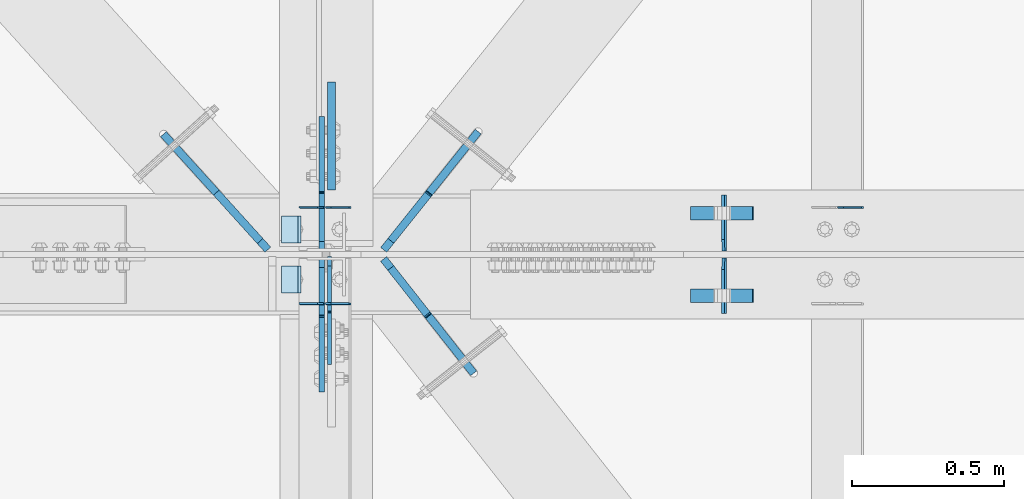
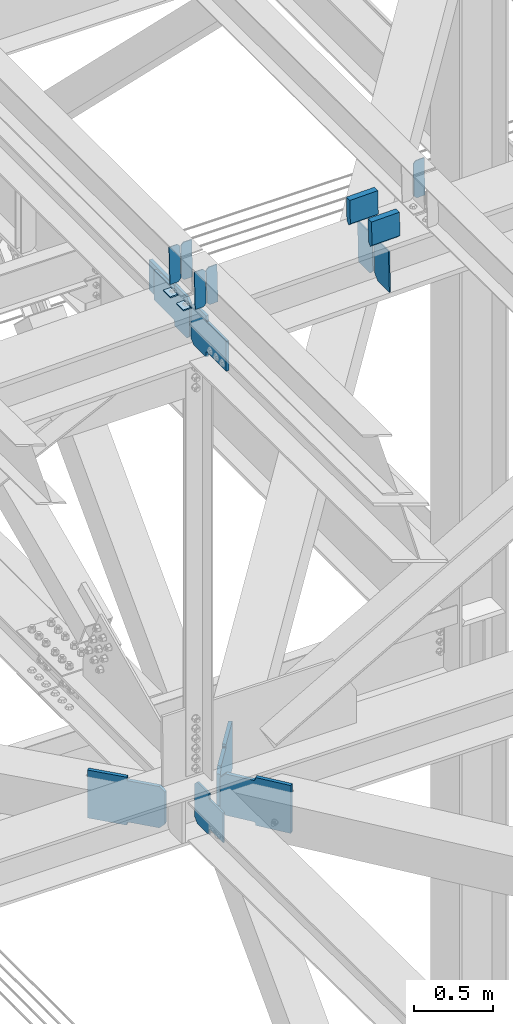
# One storey, part 3488 of 3843: 18 plates, 6 elements without a shape of their own.
"""IFC2X3 building model written with IfcOpenShell, lengths in millimetres."""

from ifc_helpers import new_model, si_unit, frame, origin_with_axes, place, context, subcontext, project, spatial, faceted_brep, material, type_object, element, aggregate, save


model = new_model("IFC2X3")

# Units and contexts
model_context = context("Model", 3, precision=1e-05, world=origin_with_axes())
body_context = subcontext(model_context, "Body", "Model", "MODEL_VIEW")
ifc_project = project(units=[si_unit("LENGTHUNIT", "METRE", prefix="MILLI"), si_unit("AREAUNIT", "SQUARE_METRE"), si_unit("VOLUMEUNIT", "CUBIC_METRE"), si_unit("MASSUNIT", "GRAM", prefix="KILO"), si_unit("TIMEUNIT", "SECOND"), si_unit("PLANEANGLEUNIT", "RADIAN"), si_unit("SOLIDANGLEUNIT", "STERADIAN"), si_unit("THERMODYNAMICTEMPERATUREUNIT", "DEGREE_CELSIUS"), si_unit("LUMINOUSINTENSITYUNIT", "LUMEN")], contexts=[model_context])

# Site, building, storey
site_placement = place(None, origin_with_axes())
site = spatial("IfcSite", under=ifc_project, at=site_placement, CompositionType="ELEMENT")
building_placement = place(site_placement, origin_with_axes())
building = spatial("IfcBuilding", under=site, at=building_placement, Name="Undefined", CompositionType="ELEMENT")
storey_placement = place(building_placement, origin_with_axes())
storey = spatial("IfcBuildingStorey", under=building, at=storey_placement, Name="Undefined", CompositionType="ELEMENT", Elevation=0.0)

# Assembly, plates
assembly_1_placement = place(storey_placement, origin_with_axes())
assembly_1 = element("IfcElementAssembly", 1, at=assembly_1_placement, inside=storey, Name="BEAM", AssemblyPlace="NOTDEFINED", PredefinedType="RIGID_FRAME")
ifc_material = material(Name="STEEL/A572-50")
plate_type_1 = type_object("IfcPlateType", PredefinedType="NOTDEFINED")
plate_1_placement = place(assembly_1_placement, frame((70338.6964783819, 84140.1262089533, 46159.7668452327), z_axis=(-0.0211520977514592, 0.00183800499970675, 0.999774579842043), x_axis=(-0.999776269352655, -3.88860000349027e-05, -0.021152062007432)))
plate_1 = element("IfcPlate", 2, at=plate_1_placement, type_object=plate_type_1, material=ifc_material, Name="PLATE", context=body_context, shape_type="Brep", body=[
    faceted_brep([(0.0, -3.17499999999927, 0.0), (6.83940015733242e-10, -3.17499999996653, 288.924999998613), (6.54836185276508e-10, 3.17500000001746, 288.924999998591), (0.0, 3.17499999999927, 0.0), (60.3250007643655, -3.17500000017753, 288.924999998606), (60.3250007643219, 3.17499999979918, 288.924999998584), (79.3750000013097, -3.17500000025029, 269.875000761494), (79.375000001266, 3.17499999972642, 269.875000761487), (79.375000000713, -3.17500000026484, 19.0499992370605), (79.3750000006985, 3.17499999971187, 19.0499992370533), (60.325000763667, -3.17500000020664, -1.45519152283669e-11), (60.3250007636234, 3.17499999977736, -3.63797880709171e-11)], [[[0, 1, 2, 3]], [[1, 4, 5, 2]], [[4, 6, 7, 5]], [[6, 8, 9, 7]], [[8, 10, 11, 9]], [[10, 0, 3, 11]], [[5, 7, 9, 11, 3, 2]], [[10, 8, 6, 4, 1, 0]]]),
])
plate_2_placement = place(assembly_1_placement, frame((70252.9906576917, 84140.1228754193, 46157.9535846961), z_axis=(-0.0211520977514592, 0.00183800499970675, 0.999774579842043), x_axis=(-0.999776269352655, -3.88860000349027e-05, -0.021152062007432)))
plate_2 = element("IfcPlate", 3, at=plate_2_placement, type_object=plate_type_1, material=ifc_material, Name="PLATE", context=body_context, shape_type="Brep", body=[
    faceted_brep([(4.36557456851006e-11, -3.17499999998836, 19.0499992370969), (6.11180439591408e-10, -3.17499999996653, 269.875000761516), (5.96628524363041e-10, 3.17500000001746, 269.875000761502), (1.45519152283669e-11, 3.17499999998836, 19.0499992370824), (19.0499992376572, -3.17500000003201, 288.924999998606), (19.0499992376281, 3.1749999999447, 288.924999998584), (79.3750000013242, -3.17500000025029, 288.924999998591), (79.3750000013097, 3.1749999997337, 288.92499999857), (79.3750000006548, -3.17500000026484, -2.18278728425503e-11), (79.3750000006403, 3.17499999969732, -2.91038304567337e-11), (19.0499992370023, -3.17500000005384, 0.0), (19.0499992369587, 3.17499999992287, -1.45519152283669e-11)], [[[0, 1, 2, 3]], [[1, 4, 5, 2]], [[4, 6, 7, 5]], [[6, 8, 9, 7]], [[8, 10, 11, 9]], [[10, 0, 3, 11]], [[5, 7, 9, 11, 3, 2]], [[10, 8, 6, 4, 1, 0]]]),
])

assembly_2_placement = place(storey_placement, origin_with_axes())
assembly_2 = element("IfcElementAssembly", 4, at=assembly_2_placement, inside=storey, Name="BEAM", AssemblyPlace="NOTDEFINED", PredefinedType="RIGID_FRAME")
plate_3_placement = place(assembly_2_placement, frame((70338.6964783509, 83820.9062473809, 46161.3065349076), z_axis=(-0.0211520981982467, 0.00763743000170506, 0.999747097222483), x_axis=(-0.999776269343203, -0.000161584000118267, -0.0211514810072338)))
plate_3 = element("IfcPlate", 5, at=plate_3_placement, type_object=plate_type_1, material=ifc_material, Name="PLATE", context=body_context, shape_type="Brep", body=[
    faceted_brep([(0.0, -3.17499999999927, 0.0), (6.83940015733242e-10, -3.17499999996653, 288.924999998613), (6.54836185276508e-10, 3.17500000001746, 288.924999998591), (0.0, 3.17499999999927, 0.0), (60.3250007643655, -3.17500000017753, 288.924999998606), (60.3250007643219, 3.17499999979918, 288.924999998584), (79.3750000013097, -3.17500000025029, 269.875000761494), (79.375000001266, 3.17499999972642, 269.875000761487), (79.375000000713, -3.17500000026484, 19.0499992370605), (79.3750000006985, 3.17499999971187, 19.0499992370533), (60.325000763667, -3.17500000020664, -1.45519152283669e-11), (60.3250007636234, 3.17499999977736, -3.63797880709171e-11)], [[[0, 1, 2, 3]], [[1, 4, 5, 2]], [[4, 6, 7, 5]], [[6, 8, 9, 7]], [[8, 10, 11, 9]], [[10, 0, 3, 11]], [[5, 7, 9, 11, 3, 2]], [[10, 8, 6, 4, 1, 0]]]),
])
plate_4_placement = place(assembly_2_placement, frame((70252.9906576605, 83820.8923956074, 46159.4933242146), z_axis=(-0.0211520981982467, 0.00763743000170506, 0.999747097222483), x_axis=(-0.999776269343203, -0.000161584000118267, -0.0211514810072338)))
plate_4 = element("IfcPlate", 6, at=plate_4_placement, type_object=plate_type_1, material=ifc_material, Name="PLATE", context=body_context, shape_type="Brep", body=[
    faceted_brep([(4.36557456851006e-11, -3.17499999998836, 19.0499992370969), (6.11180439591408e-10, -3.17499999996653, 269.875000761516), (5.96628524363041e-10, 3.17500000001746, 269.875000761502), (1.45519152283669e-11, 3.17499999998836, 19.0499992370824), (19.0499992376572, -3.17500000003201, 288.924999998606), (19.0499992376281, 3.1749999999447, 288.924999998584), (79.3750000013242, -3.17500000025029, 288.924999998591), (79.3750000013097, 3.1749999997337, 288.92499999857), (79.3750000006548, -3.17500000026484, -2.18278728425503e-11), (79.3750000006403, 3.17499999969732, -2.91038304567337e-11), (19.0499992370023, -3.17500000005384, 0.0), (19.0499992369587, 3.17499999992287, -1.45519152283669e-11)], [[[0, 1, 2, 3]], [[1, 4, 5, 2]], [[4, 6, 7, 5]], [[6, 8, 9, 7]], [[8, 10, 11, 9]], [[10, 0, 3, 11]], [[5, 7, 9, 11, 3, 2]], [[10, 8, 6, 4, 1, 0]]]),
])

# Assembly, plate
assembly_3_placement = place(storey_placement, origin_with_axes())
assembly_3 = element("IfcElementAssembly", 7, at=assembly_3_placement, inside=storey, Name="BEAM", AssemblyPlace="NOTDEFINED", PredefinedType="RIGID_FRAME")
plate_5_placement = place(assembly_3_placement, frame((72027.7964783475, 84140.0986588456, 46196.3035666869), z_axis=(-0.0211520984278759, 0.00193018200022925, 0.999774406118472), x_axis=(-0.999776269338344, -4.08370000134752e-05, -0.0211520590071558)))
plate_5 = element("IfcPlate", 8, at=plate_5_placement, type_object=plate_type_1, material=ifc_material, Name="PLATE", context=body_context, shape_type="Brep", body=[
    faceted_brep([(0.0, -3.17499999999927, 0.0), (6.83940015733242e-10, -3.17499999996653, 288.924999998613), (6.54836185276508e-10, 3.17500000001746, 288.924999998591), (0.0, 3.17499999999927, 0.0), (60.3250007643655, -3.17500000017753, 288.924999998606), (60.3250007643219, 3.17499999979918, 288.924999998584), (79.3750000013097, -3.17500000025029, 269.875000761494), (79.375000001266, 3.17499999972642, 269.875000761487), (79.375000000713, -3.17500000026484, 19.0499992370605), (79.3750000006985, 3.17499999971187, 19.0499992370533), (60.325000763667, -3.17500000020664, -1.45519152283669e-11), (60.3250007636234, 3.17499999977736, -3.63797880709171e-11)], [[[0, 1, 2, 3]], [[1, 4, 5, 2]], [[4, 6, 7, 5]], [[6, 8, 9, 7]], [[8, 10, 11, 9]], [[10, 0, 3, 11]], [[5, 7, 9, 11, 3, 2]], [[10, 8, 6, 4, 1, 0]]]),
])
aggregate(assembly_3, [plate_5])

# Assembly, plates
assembly_4_placement = place(storey_placement, origin_with_axes())
assembly_4 = element("IfcElementAssembly", 9, at=assembly_4_placement, inside=storey, Name="BEAM", AssemblyPlace="NOTDEFINED", PredefinedType="RIGID_FRAME")
plate_type_2 = type_object("IfcPlateType", PredefinedType="NOTDEFINED")
plate_6_placement = place(assembly_4_placement, frame((71572.1678113565, 83789.8375, 45819.98476757), z_axis=(-0.0216342480057937, 0.0, 0.999765952267441), x_axis=(0.0, 1.0, 0.0)))
plate_6 = element("IfcPlate", 10, at=plate_6_placement, type_object=plate_type_2, material=ifc_material, Name="PL", context=body_context, shape_type="Brep", body=[
    faceted_brep([(0.0, -4.76249999999709, 0.0), (0.0, -4.76249999785796, 317.500000005042), (0.0, 4.76250000210712, 317.50000000505), (0.0, 4.76249999999709, 0.0), (146.050001525873, -4.76249999785796, 317.500000005042), (146.050001525873, 4.76250000210712, 317.50000000505), (184.149999999994, -4.76249999810534, 279.400001530797), (184.149999999994, 4.76250000185973, 279.400001530805), (184.149999999994, -4.7624999997206, 38.0999984742448), (184.149999999994, 4.76250000022992, 38.0999984742448), (146.049999999988, -4.76250000000073, 0.0), (146.049999999988, 4.76250000000073, 0.0)], [[[0, 1, 2, 3]], [[1, 4, 5, 2]], [[4, 6, 7, 5]], [[6, 8, 9, 7]], [[8, 10, 11, 9]], [[10, 0, 3, 11]], [[5, 7, 9, 11, 3, 2]], [[10, 8, 6, 4, 1, 0]]]),
])
plate_7_placement = place(assembly_4_placement, frame((71572.1678113565, 83996.2125, 45819.98476757), z_axis=(-0.0216342480057937, 0.0, 0.999765952267441), x_axis=(0.0, 1.0, 0.0)))
plate_7 = element("IfcPlate", 11, at=plate_7_placement, type_object=plate_type_2, material=ifc_material, Name="PL", context=body_context, shape_type="Brep", body=[
    faceted_brep([(0.0, -4.76250000000073, 38.0999999999985), (0.0, -4.76249999810534, 279.400001530797), (0.0, 4.76250000185973, 279.400001530805), (0.0, 4.76250000000073, 38.0999999999985), (38.0999984741211, -4.76249999785796, 317.500000005042), (38.0999984741211, 4.76250000210712, 317.50000000505), (184.150000000009, -4.76249999999709, 317.5), (184.150000000009, 4.76249999999709, 317.5), (184.150000000009, -4.76249999999709, 0.0), (184.150000000009, 4.76249999999709, 0.0), (38.0999984741211, -4.76249999996799, 0.0), (38.0999984741211, 4.76249999998254, 0.0)], [[[0, 1, 2, 3]], [[1, 4, 5, 2]], [[4, 6, 7, 5]], [[6, 8, 9, 7]], [[8, 10, 11, 9]], [[10, 0, 3, 11]], [[5, 7, 9, 11, 3, 2]], [[10, 8, 6, 4, 1, 0]]]),
])
plate_type_3 = type_object("IfcPlateType", PredefinedType="NOTDEFINED")
plate_8_placement = place(assembly_4_placement, frame((71458.4330476478, 84121.228125, 46376.3164907603), z_axis=(0.0217666070074993, 0.0, -0.999763079343992), x_axis=(0.999763079343992, 0.0, 0.0217666070075027)))
plate_8 = element("IfcPlate", 12, at=plate_8_placement, type_object=plate_type_3, material=ifc_material, Name="PLATE", context=body_context, shape_type="Brep", body=[
    faceted_brep([(203.200005058941, -22.2250000000058, -1.16415321826935e-10), (7.27595761418343e-12, -22.2250000000058, -7.27595761418343e-12), (7.27595761418343e-12, 22.2250000000058, -7.27595761418343e-12), (203.200005058941, 22.2250000000058, -1.16415321826935e-10), (203.838531807472, -22.2250000000058, 0.00187068080413155), (203.838531807472, 22.2250000000058, 0.00187068080413155), (203.310341304641, -22.2250000000058, 180.861817383484), (0.04046799018397, -22.2250000000058, 180.907287948779), (203.245434494536, 0.0133131837355904, 203.086833080139), (0.0454396034692763, 0.0133129994646879, 203.132287829787), (0.0404679902494536, 22.2250000000058, 180.907288225317), (203.310341303353, 22.2250000000058, 180.861817822159)], [[[0, 1, 2, 3]], [[4, 0, 3, 5]], [[1, 0, 4, 6, 7]], [[7, 6, 8, 9]], [[2, 1, 7, 9, 10]], [[5, 3, 2, 10, 11]], [[6, 4, 5, 11, 8]], [[10, 9, 8, 11]]]),
])
plate_9_placement = place(assembly_4_placement, frame((71458.4330476478, 83848.178125, 46376.3164907603), z_axis=(0.0217666070074993, 0.0, -0.999763079343992), x_axis=(0.999763079343992, 0.0, 0.0217666070075027)))
plate_9 = element("IfcPlate", 13, at=plate_9_placement, type_object=plate_type_3, material=ifc_material, Name="PLATE", context=body_context, shape_type="Brep", body=[
    faceted_brep([(203.200005058941, -22.2250000000058, -1.16415321826935e-10), (7.27595761418343e-12, -22.2250000000058, -7.27595761418343e-12), (7.27595761418343e-12, 22.2250000000058, -7.27595761418343e-12), (203.200005058941, 22.2250000000058, -1.16415321826935e-10), (203.838531807472, -22.2250000000058, 0.00187068080413155), (203.838531807472, 22.2250000000058, 0.00187068080413155), (203.310341304641, -22.2250000000058, 180.861817383484), (0.04046799018397, -22.2250000000058, 180.907287948779), (203.245434494536, 0.0133131837355904, 203.086833080139), (0.0454396034692763, 0.0133129994646879, 203.132287829787), (0.0404679902494536, 22.2250000000058, 180.907288225317), (203.310341303353, 22.2250000000058, 180.861817822159)], [[[0, 1, 2, 3]], [[4, 0, 3, 5]], [[1, 0, 4, 6, 7]], [[7, 6, 8, 9]], [[2, 1, 7, 9, 10]], [[5, 3, 2, 10, 11]], [[6, 4, 5, 11, 8]], [[10, 9, 8, 11]]]),
])

# Plate
plate_type_4 = type_object("IfcPlateType", PredefinedType="NOTDEFINED")
plate_10_placement = place(assembly_1_placement, frame((70173.7677266369, 84112.0999999999, 46150.2113018201), z_axis=(0.0, -1.0, 0.0), x_axis=(-0.999776270257024, 0.0, -0.0211520550054595)))
plate_10 = element("IfcPlate", 14, at=plate_10_placement, type_object=plate_type_4, material=ifc_material, Name="PLATE", context=body_context, shape_type="Brep", body=[
    faceted_brep([(9.52499999982683, -4.7625000001135, 88.8999999999942), (0.0, 4.76249999999709, 88.9000015258789), (0.0, 4.76249999999709, 0.0), (9.52499999981956, -4.76249999999709, 0.0), (63.4999984608512, -4.76249999988795, 88.8999999999796), (63.4999984608367, -4.76249999988795, -1.45519152283669e-11), (63.4999984608221, 4.76250000013533, -1.45519152283669e-11), (63.4999984608367, 4.76250000013533, 88.8999999999796)], [[[0, 1, 2, 3]], [[4, 5, 6, 7]], [[5, 4, 0, 3]], [[6, 5, 3, 2]], [[7, 6, 2, 1]], [[4, 7, 1, 0]]]),
])

aggregate(assembly_1, [plate_1, plate_2, plate_10])

plate_11_placement = place(assembly_2_placement, frame((70173.7677266369, 83947.0000015258, 46150.2113018201), z_axis=(0.0, -1.0, 0.0), x_axis=(-0.999776270257024, 0.0, -0.0211520550054595)))
plate_11 = element("IfcPlate", 15, at=plate_11_placement, type_object=plate_type_4, material=ifc_material, Name="PLATE", context=body_context, shape_type="Brep", body=[
    faceted_brep([(9.52499999982683, -4.7625000001135, 88.8999999999942), (0.0, 4.76249999999709, 88.9000015258789), (0.0, 4.76249999999709, 0.0), (9.52499999981956, -4.76249999999709, 0.0), (63.4999984608512, -4.76249999988795, 88.8999999999796), (63.4999984608367, -4.76249999988795, -1.45519152283669e-11), (63.4999984608221, 4.76250000013533, -1.45519152283669e-11), (63.4999984608367, 4.76250000013533, 88.8999999999796)], [[[0, 1, 2, 3]], [[4, 5, 6, 7]], [[5, 4, 0, 3]], [[6, 5, 3, 2]], [[7, 6, 2, 1]], [[4, 7, 1, 0]]]),
])

aggregate(assembly_2, [plate_3, plate_4, plate_11])

# Assembly, plate
assembly_5_placement = place(storey_placement, origin_with_axes())
assembly_5 = element("IfcElementAssembly", 16, at=assembly_5_placement, inside=storey, Name="BEAM", AssemblyPlace="NOTDEFINED", PredefinedType="RIGID_FRAME")
plate_type_5 = type_object("IfcPlateType", PredefinedType="NOTDEFINED")
plate_12_placement = place(assembly_5_placement, frame((70267.5125000302, 83977.9562500182, 42135.819818912), z_axis=(0.0, -0.707106781186682, 0.707106781186413), x_axis=(0.0, -0.707106781186548, -0.707106781186548)))
plate_12 = element("IfcPlate", 17, at=plate_12_placement, type_object=plate_type_5, material=ifc_material, Name="PLATE", context=body_context, shape_type="Brep", body=[
    faceted_brep([(0.0, -6.3499999046162, 0.0), (-179.600813047069, -6.35000000000582, 179.600813047073), (-179.600813047069, 6.35000000000582, 179.600813047073), (7.27595761418343e-12, 6.3499999046162, 0.0), (-179.600813047073, -6.35000000000582, 224.502093652191), (-179.600813047073, 6.35000000000582, 224.502093652191), (-75.7666016477051, -6.35000000000582, 328.336305051562), (-75.7666016477051, 6.35000000000582, 328.336305051562), (-54.6267979619151, -6.35000000000582, 307.196501396702), (-54.6267979619151, 6.35000000000582, 307.196501396702), (-50.5066214937542, -6.35000000000582, 304.443487496235), (-50.5066214937542, 6.35000000000582, 304.443487496235), (-45.6465419757005, -6.35000000000582, 303.476757573677), (-45.6465419757005, 6.35000000000582, 303.476757573677), (-40.7864624576323, -6.35000000000582, 304.443487496279), (-40.7864624576323, 6.35000000000582, 304.443487496279), (-36.6662859894568, -6.35000000000582, 307.196501396786), (-36.6662859894568, 6.35000000000582, 307.196501396786), (80.0770437083847, -6.35000000000582, 423.939831094605), (80.0770437083847, 6.35000000000582, 423.939831094605), (241.721653886838, -6.35000000000582, 262.295220916116), (241.721653886838, 6.35000000000582, 262.295220916116), (124.978324188996, -6.35000000000582, 145.551891218296), (124.978324188996, 6.35000000000582, 145.551891218296), (122.225310288486, -6.35000000000582, 141.431714750117), (122.225310288486, 6.35000000000582, 141.431714750117), (121.258580365873, -6.35000000000582, 136.571635232071), (121.258580365873, 6.35000000000582, 136.571635232071), (122.225310288428, -6.35000000000582, 131.711555714002), (122.225310288428, 6.35000000000582, 131.711555714002), (124.978324188909, -6.35000000000582, 127.591379245863), (124.978324188909, 6.35000000000582, 127.591379245863), (148.735492004496, -6.35000000000582, 103.834211399357), (148.735492004496, 6.35000000000582, 103.834211399357), (44.9012806051323, -6.35000000000582, -1.45519152283669e-11), (44.9012806051323, 6.35000000000582, -1.45519152283669e-11)], [[[0, 1, 2, 3]], [[1, 4, 5, 2]], [[4, 6, 7, 5]], [[6, 8, 9, 7]], [[8, 10, 11, 9]], [[10, 12, 13, 11]], [[12, 14, 15, 13]], [[14, 16, 17, 15]], [[16, 18, 19, 17]], [[18, 20, 21, 19]], [[20, 22, 23, 21]], [[22, 24, 25, 23]], [[24, 26, 27, 25]], [[26, 28, 29, 27]], [[28, 30, 31, 29]], [[30, 32, 33, 31]], [[32, 34, 35, 33]], [[34, 0, 3, 35]], [[5, 7, 9, 11, 13, 15, 17, 19, 21, 23, 25, 27, 29, 31, 33, 35, 3, 2]], [[34, 32, 30, 28, 26, 24, 22, 20, 18, 16, 14, 12, 10, 8, 6, 4, 1, 0]]]),
])

# Plate
plate_type_6 = type_object("IfcPlateType", PredefinedType="NOTDEFINED")
plate_13_placement = place(assembly_4_placement, frame((70242.1124998361, 83996.2125, 45823.1590276267), z_axis=(0.0, 0.707106781186548, 0.707106781186548), x_axis=(5.70000238222118e-08, 0.707106781186546, -0.707106781186546)))
plate_13 = element("IfcPlate", 18, at=plate_13_placement, type_object=plate_type_6, material=ifc_material, Name="PLATE", context=body_context, shape_type="Brep", body=[
    faceted_brep([(0.0, -9.52500000000146, 0.0), (-179.366715657274, -9.52499999999418, 179.366715657248), (-179.366715657274, 9.52499999999418, 179.366715657248), (0.0, 9.52500000000146, 0.0), (-179.366715656826, -9.52499999999418, 224.267996262832), (-179.366715656826, 9.52499999999418, 224.267996262832), (-68.2360461568533, -9.52499999999418, 335.398665762827), (-68.2360461568533, 9.52499999999418, 335.398665762827), (-46.1232264977771, -9.52499999999418, 313.285846103783), (-46.1232264977771, 9.52499999999418, 313.285846103783), (-42.003050029638, -9.52499999999418, 310.532832203317), (-42.003050029638, 9.52499999999418, 310.532832203317), (-37.1429705115806, -9.52499999999418, 309.566102280762), (-37.1429705115806, 9.52499999999418, 309.566102280762), (-32.2828909935233, -9.52499999999418, 310.53283220336), (-32.2828909935233, 9.52499999999418, 310.53283220336), (-28.1627145253442, -9.52499999999418, 313.28584610387), (-28.1627145253442, 9.52499999999418, 313.28584610387), (142.462151912587, -9.52499999999418, 483.910712541838), (142.462151912587, 9.52499999999418, 483.910712541838), (304.106762091076, -9.52499999999418, 322.266102363385), (304.106762091076, 9.52499999999418, 322.266102363385), (133.481895653153, -9.52499999999418, 151.641235925432), (133.481895653153, 9.52499999999418, 151.641235925432), (130.728881752639, -9.52499999999418, 147.521059457242), (130.728881752639, 9.52499999999418, 147.521059457242), (129.762151830029, -9.52499999999418, 142.660979939188), (129.762151830029, 9.52499999999418, 142.660979939188), (130.728881752595, -9.52499999999418, 137.80090042112), (130.728881752595, 9.52499999999418, 137.80090042112), (133.481895653069, -9.52499999999418, 133.680723952973), (133.481895653069, 9.52499999999418, 133.680723952973), (156.031950102854, -9.52499999999418, 111.130669497732), (156.031950102854, 9.52499999999418, 111.130669497732), (44.9012806055835, -9.52499999999418, 4.65661287307739e-10), (44.9012806055835, 9.52499999999418, 4.65661287307739e-10)], [[[0, 1, 2, 3]], [[1, 4, 5, 2]], [[4, 6, 7, 5]], [[6, 8, 9, 7]], [[8, 10, 11, 9]], [[10, 12, 13, 11]], [[12, 14, 15, 13]], [[14, 16, 17, 15]], [[16, 18, 19, 17]], [[18, 20, 21, 19]], [[20, 22, 23, 21]], [[22, 24, 25, 23]], [[24, 26, 27, 25]], [[26, 28, 29, 27]], [[28, 30, 31, 29]], [[30, 32, 33, 31]], [[32, 34, 35, 33]], [[34, 0, 3, 35]], [[5, 7, 9, 11, 13, 15, 17, 19, 21, 23, 25, 27, 29, 31, 33, 35, 3, 2]], [[34, 32, 30, 28, 26, 24, 22, 20, 18, 16, 14, 12, 10, 8, 6, 4, 1, 0]]]),
])

plate_14_placement = place(assembly_4_placement, frame((70242.1125704583, 83973.9874999824, 45823.1590291386), z_axis=(0.0, -0.707106781186682, 0.707106781186413), x_axis=(0.0, -0.707106781186548, -0.707106781186548)))
plate_14 = element("IfcPlate", 19, at=plate_14_placement, type_object=plate_type_6, material=ifc_material, Name="PLATE", context=body_context, shape_type="Brep", body=[
    faceted_brep([(0.0, -9.52500000000146, 0.0), (-179.366715657274, -9.52499999999418, 179.366715657248), (-179.366715657274, 9.52499999999418, 179.366715657248), (0.0, 9.52500000000146, 0.0), (-179.366715656826, -9.52499999999418, 224.267996262832), (-179.366715656826, 9.52499999999418, 224.267996262832), (-68.2360461568533, -9.52499999999418, 335.398665762827), (-68.2360461568533, 9.52499999999418, 335.398665762827), (-47.5125439119147, -9.52499999999418, 314.675163491531), (-47.5125439119147, 9.52499999999418, 314.675163491531), (-43.3923674437683, -9.52499999999418, 311.92214959105), (-43.3923674437683, 9.52499999999418, 311.92214959105), (-38.5322879257146, -9.52499999999418, 310.955419668495), (-38.5322879257146, 9.52499999999418, 310.955419668495), (-33.6722084076464, -9.52499999999418, 311.922149591101), (-33.6722084076464, 9.52499999999418, 311.922149591101), (-29.5520319394709, -9.52499999999418, 314.675163491615), (-29.5520319394709, 9.52499999999418, 314.675163491615), (141.07283451168, -9.52499999999418, 485.300029942751), (141.07283451168, 9.52499999999418, 485.300029942751), (302.717444690134, -9.52499999999418, 323.655419764294), (302.717444690134, 9.52499999999418, 323.655419764294), (132.092578238997, -9.52499999999418, 153.03055331315), (132.092578238997, 9.52499999999418, 153.03055331315), (129.339564338487, -9.52499999999418, 148.910376844968), (129.339564338487, 9.52499999999418, 148.910376844968), (128.372834415874, -9.52499999999418, 144.050297326903), (128.372834415874, 9.52499999999418, 144.050297326903), (129.339564338443, -9.52499999999418, 139.190217808849), (129.339564338443, 9.52499999999418, 139.190217808849), (132.092578238909, -9.52499999999418, 135.070041340707), (132.092578238909, 9.52499999999418, 135.070041340707), (156.031950102854, -9.52499999999418, 111.130669497732), (156.031950102854, 9.52499999999418, 111.130669497732), (44.9012806055835, -9.52499999999418, 4.65661287307739e-10), (44.9012806055835, 9.52499999999418, 4.65661287307739e-10)], [[[0, 1, 2, 3]], [[1, 4, 5, 2]], [[4, 6, 7, 5]], [[6, 8, 9, 7]], [[8, 10, 11, 9]], [[10, 12, 13, 11]], [[12, 14, 15, 13]], [[14, 16, 17, 15]], [[16, 18, 19, 17]], [[18, 20, 21, 19]], [[20, 22, 23, 21]], [[22, 24, 25, 23]], [[24, 26, 27, 25]], [[26, 28, 29, 27]], [[28, 30, 31, 29]], [[30, 32, 33, 31]], [[32, 34, 35, 33]], [[34, 0, 3, 35]], [[5, 7, 9, 11, 13, 15, 17, 19, 21, 23, 25, 27, 29, 31, 33, 35, 3, 2]], [[34, 32, 30, 28, 26, 24, 22, 20, 18, 16, 14, 12, 10, 8, 6, 4, 1, 0]]]),
])

aggregate(assembly_4, [plate_6, plate_7, plate_8, plate_9, plate_13, plate_14])

# Assembly, plate
assembly_6_placement = place(storey_placement, origin_with_axes())
assembly_6 = element("IfcElementAssembly", 20, at=assembly_6_placement, inside=storey, Name="BEAM", AssemblyPlace="NOTDEFINED", PredefinedType="RIGID_FRAME")
plate_type_7 = type_object("IfcPlateType", PredefinedType="NOTDEFINED")
plate_15_placement = place(assembly_6_placement, frame((70273.862508558, 84553.4249947556, 45835.9996202807), z_axis=(0.0, -1.0, 0.0), x_axis=(0.0, 0.0, 1.0)))
plate_15 = element("IfcPlate", 21, at=plate_15_placement, type_object=plate_type_7, material=ifc_material, Name="PLATE", context=body_context, shape_type="Brep", body=[
    faceted_brep([(0.0, -12.6999999999971, 0.0), (0.0, -12.7000000000007, 355.600000000006), (0.0, 12.7000000000007, 355.600000000006), (0.0, 12.6999999999971, 0.0), (228.599998464349, -12.7000000013795, 355.599999691767), (228.599998464349, 12.6999999986292, 355.599999691869), (228.599999999991, -12.7000007629103, -5.82076609134674e-10), (228.59998398881, 12.6999999999971, -9.82254277914762e-10)], [[[0, 1, 2, 3]], [[1, 4, 5, 2]], [[4, 6, 7, 5]], [[6, 0, 3, 7]], [[5, 7, 3, 2]], [[6, 4, 1, 0]]]),
])
aggregate(assembly_6, [plate_15])

# Plate
plate_type_8 = type_object("IfcPlateType", PredefinedType="NOTDEFINED")
plate_16_placement = place(assembly_5_placement, frame((70446.0081210455, 83970.1005313788, 42104.1529332383), z_axis=(0.0, 0.0, 1.0), x_axis=(0.618560525050801, -0.785737155064515, 0.0)))
plate_16 = element("IfcPlate", 22, at=plate_16_placement, type_object=plate_type_8, material=ifc_material, Name="STIFFENER", context=body_context, shape_type="Brep", body=[
    faceted_brep([(0.0, -12.6999999999971, 38.0999999999913), (1.57808244694024e-07, -12.7000000000698, 279.400255757311), (1.5777550288476e-07, 12.6999999998807, 279.400255757319), (0.0, 12.6999999999971, 38.0999999999913), (38.0999986533716, -12.7000000000262, 317.500254231185), (38.0999986533352, 12.6999999999243, 317.500254231192), (227.293955966772, -12.6999999999607, 317.500254232153), (227.293955966772, 12.7000000000189, 317.50025423216), (232.154035484622, -12.6999999999607, 318.466984154678), (232.154035484622, 12.7000000000262, 318.466984154686), (236.274211952652, -12.6999999999462, 321.219998054963), (236.274211952667, 12.7000000000189, 321.21999805497), (239.027225853148, -12.6999999999534, 325.340174522848), (239.027225853162, 12.7000000000189, 325.340174522855), (239.993955775935, -12.6999999999534, 330.200254040647), (239.99395577595, 12.7000000000262, 330.200254040654), (239.993955776663, -12.6999999999462, 342.900254232183), (239.993955776677, 12.7000000000189, 342.90025423219), (479.812102647542, -12.6999999999898, 342.900254225504), (479.812102647556, 12.6999999999753, 342.900254225511), (479.812102402619, -12.700000000099, -25.4000000013548), (479.812102402619, 12.6999999998661, -25.4000000013475), (239.993955700993, -12.700000000048, -25.4000000000015), (239.993955700993, 12.6999999999243, -25.3999999999942), (239.99395570159, -12.7000000000407, -12.69999980992), (239.99395570159, 12.6999999999243, -12.69999980992), (239.027225779166, -12.7000000000335, -7.83992029167712), (239.02722577918, 12.6999999999316, -7.83992029166984), (236.274211878714, -12.7000000000335, -3.71974382330518), (236.274211878728, 12.6999999999389, -3.7197438232979), (232.15403541048, -12.7000000000407, -0.966729922663944), (232.154035410495, 12.6999999999243, -0.966729922656668), (227.293955892295, -12.7000000000407, -1.45519152283669e-11), (227.293955892295, 12.6999999999389, -7.27595761418343e-12), (38.1000000000058, -12.7000000000844, 2.18278728425503e-11), (38.1000000000058, 12.7000000000262, 4.36557456851006e-11)], [[[0, 1, 2, 3]], [[1, 4, 5, 2]], [[4, 6, 7, 5]], [[6, 8, 9, 7]], [[8, 10, 11, 9]], [[10, 12, 13, 11]], [[12, 14, 15, 13]], [[14, 16, 17, 15]], [[16, 18, 19, 17]], [[18, 20, 21, 19]], [[20, 22, 23, 21]], [[22, 24, 25, 23]], [[24, 26, 27, 25]], [[26, 28, 29, 27]], [[28, 30, 31, 29]], [[30, 32, 33, 31]], [[32, 34, 35, 33]], [[34, 0, 3, 35]], [[5, 7, 9, 11, 13, 15, 17, 19, 21, 23, 25, 27, 29, 31, 33, 35, 3, 2]], [[34, 32, 30, 28, 26, 24, 22, 20, 18, 16, 14, 12, 10, 8, 6, 4, 1, 0]]]),
])

plate_17_placement = place(assembly_5_placement, frame((70064.4364723027, 84000.7620651339, 42103.9687050824), z_axis=(0.0, 0.0, 1.0), x_axis=(-0.670733509108492, 0.741698429119955, 0.0)))
plate_17 = element("IfcPlate", 23, at=plate_17_placement, type_object=plate_type_8, material=ifc_material, Name="STIFFENER", context=body_context, shape_type="Brep", body=[
    faceted_brep([(0.0, -12.6999999999971, 38.0999999999913), (1.57808244694024e-07, -12.7000000000698, 279.400255757311), (1.5777550288476e-07, 12.6999999998807, 279.400255757319), (0.0, 12.6999999999971, 38.0999999999913), (38.0999986533716, -12.7000000000262, 317.500254231185), (38.0999986533352, 12.6999999999243, 317.500254231192), (253.490250318582, -12.7000000002445, 317.500254165694), (253.490250318633, 12.6999999996769, 317.500254165672), (253.490240639017, -12.699999999717, 342.900254152992), (253.490240638959, 12.7000000002117, 342.900254153014), (513.348712221617, -12.6999999991531, 342.900254093453), (513.348712221574, 12.7000000007756, 342.900254093474), (513.348712062521, -12.6999999988329, -25.4000000039669), (513.348712062478, 12.7000000010958, -25.400000003945), (253.490240611383, -12.6999999993932, -25.4000000009328), (253.490240611325, 12.7000000005355, -25.4000000009109), (253.49024061345, -12.6999999994114, -12.6999998122337), (253.490240613392, 12.7000000005173, -12.6999998122046), (252.523510691462, -12.6999999994114, -7.83992029356159), (252.523510691404, 12.7000000005246, -7.83992029353249), (249.770496791127, -12.6999999994259, -3.71974382470216), (249.770496791083, 12.7000000005028, -3.71974382468034), (245.650320322762, -12.6999999994368, -0.966729923689854), (245.650320322704, 12.7000000004919, -0.966729923660751), (240.790240804243, -12.6999999994441, -8.87666828930378e-10), (240.790240804185, 12.7000000004919, -8.58562998473644e-10), (38.1000000000058, -12.7000000000844, 2.18278728425503e-11), (38.1000000000058, 12.7000000000262, 4.36557456851006e-11)], [[[0, 1, 2, 3]], [[1, 4, 5, 2]], [[4, 6, 7, 5]], [[6, 8, 9, 7]], [[8, 10, 11, 9]], [[10, 12, 13, 11]], [[12, 14, 15, 13]], [[14, 16, 17, 15]], [[16, 18, 19, 17]], [[18, 20, 21, 19]], [[20, 22, 23, 21]], [[22, 24, 25, 23]], [[24, 26, 27, 25]], [[26, 0, 3, 27]], [[5, 7, 9, 11, 13, 15, 17, 19, 21, 23, 25, 27, 3, 2]], [[26, 24, 22, 20, 18, 16, 14, 12, 10, 8, 6, 4, 1, 0]]]),
])

plate_18_placement = place(assembly_5_placement, frame((70446.2496090037, 84000.1736432351, 42104.153049832), z_axis=(0.0, 0.0, 1.0), x_axis=(0.624401003155509, 0.78110395419457, 0.0)))
plate_18 = element("IfcPlate", 24, at=plate_18_placement, type_object=plate_type_8, material=ifc_material, Name="STIFFENER", context=body_context, shape_type="Brep", body=[
    faceted_brep([(0.0, -12.6999999999971, 38.0999999999913), (1.57808244694024e-07, -12.7000000000698, 279.400255757311), (1.5777550288476e-07, 12.6999999998807, 279.400255757319), (0.0, 12.6999999999971, 38.0999999999913), (38.0999986533716, -12.7000000000262, 317.500254231185), (38.0999986533352, 12.6999999999243, 317.500254231192), (228.642741571588, -12.7000000014668, 317.500254166414), (228.642741571592, 12.6999999986729, 317.500254166443), (233.502821090715, -12.7000000015105, 318.466984087972), (233.502821090729, 12.6999999986438, 318.466984088001), (237.622997560055, -12.7000000015105, 321.219997988213), (237.62299756008, 12.6999999986292, 321.219997988243), (240.376011461431, -12.7000000015396, 325.340174456825), (240.376011461449, 12.6999999986147, 325.340174456847), (241.342741384324, -12.7000000015396, 330.200253975709), (241.342741384342, 12.6999999986001, 330.200253975738), (241.342741384211, -12.7000000015832, 342.900254162792), (241.342741384233, 12.6999999985565, 342.900254162822), (498.901780984004, -12.7000000020198, 342.900254094297), (498.901780984022, 12.6999999981344, 342.900254094326), (498.901780819502, -12.7000000007974, -25.4000000031519), (498.901780819524, 12.6999999993568, -25.4000000031228), (241.342741384135, -12.7000000003754, -25.4000000007727), (241.342741384142, 12.6999999997643, -25.4000000007436), (241.342741384076, -12.7000000004191, -12.6999998100073), (241.342741384084, 12.6999999997352, -12.6999998099855), (240.376011461482, -12.7000000004191, -7.83992029196816), (240.376011461482, 12.6999999997206, -7.83992029193905), (237.622997560989, -12.7000000004336, -3.7197438238145), (237.622997561011, 12.6999999997061, -3.71974382378539), (233.502821092847, -12.7000000004336, -0.966729923326056), (233.502821092861, 12.6999999997061, -0.966729923296953), (228.642741574833, -12.7000000004336, -7.20319803804159e-10), (228.642741574833, 12.6999999997061, -6.98491930961609e-10), (38.1000000000058, -12.7000000000844, 2.18278728425503e-11), (38.1000000000058, 12.7000000000262, 4.36557456851006e-11)], [[[0, 1, 2, 3]], [[1, 4, 5, 2]], [[4, 6, 7, 5]], [[6, 8, 9, 7]], [[8, 10, 11, 9]], [[10, 12, 13, 11]], [[12, 14, 15, 13]], [[14, 16, 17, 15]], [[16, 18, 19, 17]], [[18, 20, 21, 19]], [[20, 22, 23, 21]], [[22, 24, 25, 23]], [[24, 26, 27, 25]], [[26, 28, 29, 27]], [[28, 30, 31, 29]], [[30, 32, 33, 31]], [[32, 34, 35, 33]], [[34, 0, 3, 35]], [[5, 7, 9, 11, 13, 15, 17, 19, 21, 23, 25, 27, 29, 31, 33, 35, 3, 2]], [[34, 32, 30, 28, 26, 24, 22, 20, 18, 16, 14, 12, 10, 8, 6, 4, 1, 0]]]),
])

aggregate(assembly_5, [plate_12, plate_16, plate_17, plate_18])

save(model, "model.ifc")
